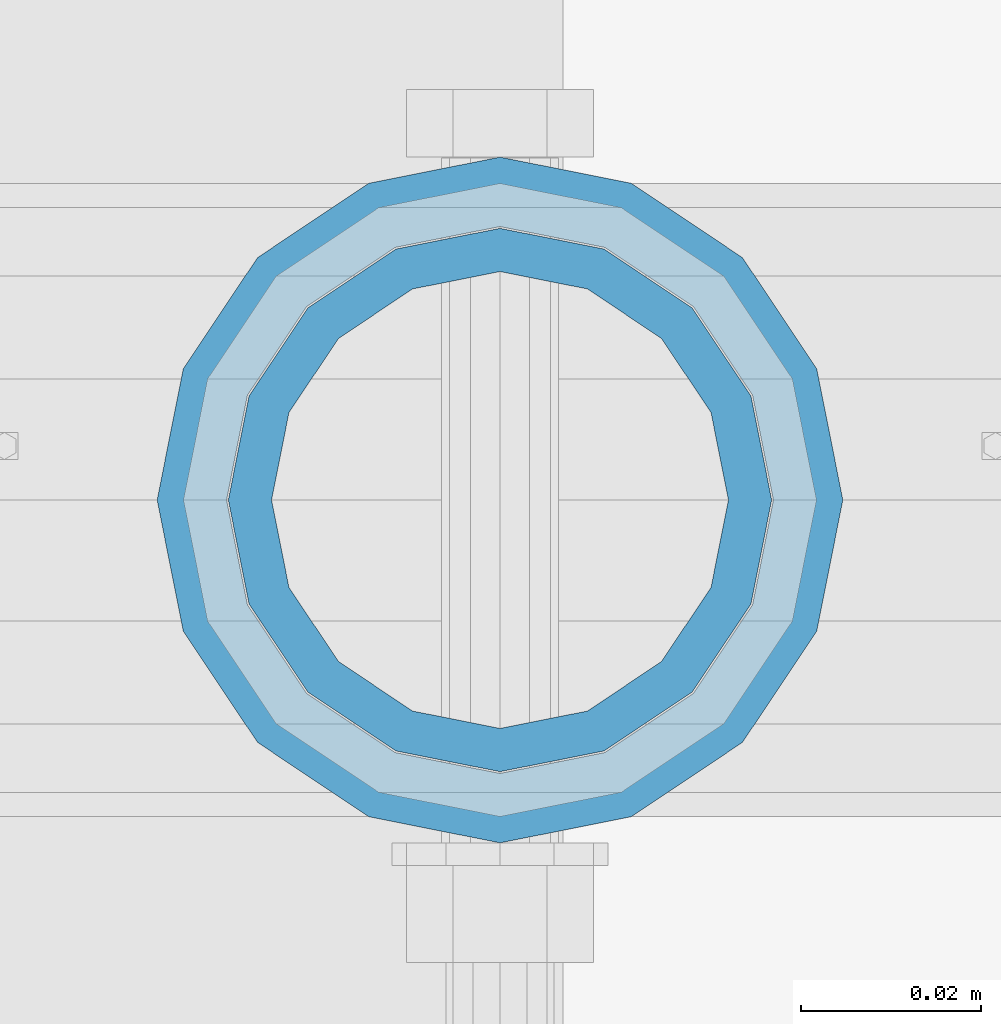
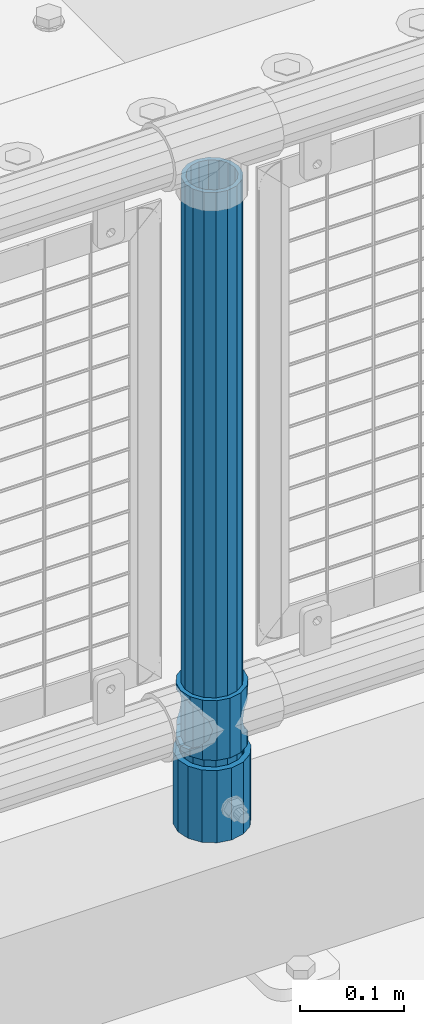
# One storey, part 67 of 193: 3 columns.
"""IFC2X3 building model written with IfcOpenShell, lengths in millimetres."""

from ifc_helpers import new_model, si_unit, frame, origin_with_axes, place, context, subcontext, project, spatial, faceted_brep, material, type_object, element, save


model = new_model("IFC2X3")

# Units and contexts
model_context = context("Model", 3, precision=1e-05, world=origin_with_axes())
body_context = subcontext(model_context, "Body", "Model", "MODEL_VIEW")
ifc_project = project(units=[si_unit("LENGTHUNIT", "METRE", prefix="MILLI"), si_unit("AREAUNIT", "SQUARE_METRE"), si_unit("VOLUMEUNIT", "CUBIC_METRE"), si_unit("MASSUNIT", "GRAM", prefix="KILO"), si_unit("TIMEUNIT", "SECOND"), si_unit("PLANEANGLEUNIT", "RADIAN"), si_unit("SOLIDANGLEUNIT", "STERADIAN"), si_unit("THERMODYNAMICTEMPERATUREUNIT", "DEGREE_CELSIUS"), si_unit("LUMINOUSINTENSITYUNIT", "LUMEN")], contexts=[model_context])

# Site, building, storey
site_placement = place(None, origin_with_axes())
site = spatial("IfcSite", under=ifc_project, at=site_placement, CompositionType="ELEMENT")
building_placement = place(site_placement, origin_with_axes())
building = spatial("IfcBuilding", under=site, at=building_placement, Name="Standard", CompositionType="ELEMENT")
storey_placement = place(building_placement, origin_with_axes())
storey = spatial("IfcBuildingStorey", under=building, at=storey_placement, Name="Undefined", CompositionType="ELEMENT", Elevation=0.0)

# Columns
ifc_material_1 = material(Name="Misc_Undefined")
column_type_1 = type_object("IfcColumnType", PredefinedType="NOTDEFINED")
column_1_placement = place(storey_placement, frame((-35197.0, 28664.5, 263.020000000001), z_axis=(-1.0, 0.0, 0.0), x_axis=(0.0, 0.0, 1.0)))
element("IfcColumn", 1, at=column_1_placement, inside=storey, type_object=column_type_1, material=ifc_material_1, context=body_context, shape_type="Brep", body=[
    faceted_brep([(56.6106908090114, 21.46069080901, -21.46069080901), (56.6106908090114, 21.46069080901, -27.1226768591041), (61.9623795176744, 13.4513226476338, -32.4743655677703), (63.1897438117172, 11.614442172282, -32.8397438117245), (63.1897438117172, 11.614442172282, -28.0397438117179), (46.7644421722801, 28.0397438117179, -11.614442172282), (46.7644421722801, 28.0397438117179, -20.0882031229849), (51.5310424080006, 24.8548033587067, -24.8548033587067), (35.1500000000015, 30.35, 0.0), (35.1499999999996, 30.3499999999985, -16.6306603983685), (23.5355578277192, 28.0397438117179, -11.614442172282), (23.5355578277192, 28.0397438117179, -20.0882031229849), (13.6893091909879, 21.46069080901, -21.46069080901), (13.6893091909879, 21.46069080901, -27.1226768591041), (18.7689575919987, 24.8548033587067, -24.8548033587067), (7.11025618828211, 11.614442172282, -28.0397438117179), (7.11025618828211, 11.614442172282, -32.8397438117245), (8.33762048232262, 13.4513226476338, -32.4743655677703), (4.79999999999961, 0.0, -30.3499999999985), (4.79999999999961, 0.0, -35.1500000000015), (7.11025618828211, -11.614442172282, -28.0397438117179), (7.11025618828211, -11.614442172282, -32.8397438117172), (13.6893091909879, -21.46069080901, -21.46069080901), (13.6893091909879, -21.46069080901, -27.1226768591114), (8.33762048232484, -13.4513226476338, -32.4743655677703), (23.5355578277191, -28.0397438117179, -11.614442172282), (23.5355578277191, -28.0397438117179, -20.0882031229812), (18.7689575919921, -24.8548033587067, -24.8548033587067), (35.1500000000015, -30.35, 0.0), (35.1499999999996, -30.3499999999985, -16.6306603983721), (46.7644421722801, -28.0397438117179, -11.614442172282), (46.7644421722801, -28.0397438117179, -20.0882031229812), (56.6106908090114, -21.46069080901, -21.46069080901), (56.6106908090114, -21.46069080901, -27.1226768591114), (51.5310424080006, -24.8548033587067, -24.8548033587067), (63.1897438117172, -11.614442172282, -28.0397438117179), (63.1897438117172, -11.614442172282, -32.8397438117172), (61.9623795176767, -13.4513226476338, -32.4743655677703), (65.4999999999997, 0.0, -30.3499999999985), (65.4999999999997, 0.0, -35.1500000000015), (0.0, -28.0397438117179, -11.614442172282), (0.0, -30.3499999999985, 0.0), (0.0, -21.46069080901, -21.46069080901), (0.0, -11.614442172282, -28.0397438117179), (0.0, 0.0, -30.3499999999985), (0.0, 11.614442172282, -28.0397438117179), (0.0, 21.46069080901, -21.46069080901), (0.0, 28.0397438117179, -11.614442172282), (0.0, 30.3499999999985, 0.0), (0.0, 28.0397438117179, 11.614442172282), (23.5355578277192, 28.0397438117179, 11.614442172282), (0.0, 21.46069080901, 21.46069080901), (13.6893091909879, 21.46069080901, 21.46069080901), (0.0, 11.614442172282, 28.0397438117179), (7.11025618828211, 11.614442172282, 28.0397438117179), (0.0, 0.0, 30.3499999999985), (4.79999999999961, 0.0, 30.3499999999985), (0.0, -11.614442172282, 28.0397438117179), (7.11025618828205, -11.614442172282, 28.0397438117179), (0.0, -21.46069080901, 21.46069080901), (13.6893091909879, -21.46069080901, 21.46069080901), (0.0, -28.0397438117179, 11.614442172282), (23.5355578277191, -28.0397438117179, 11.614442172282), (0.0, -32.4743655677703, 13.4513226476338), (0.0, -35.1500000000015, 0.0), (70.2999999999993, -35.1500000000015, 0.0), (70.2999999999993, -32.4743655677703, 13.4513226476338), (0.0, 13.4513226476338, -32.4743655677703), (0.0, 24.8548033587067, -24.8548033587067), (0.0, 0.0, -35.1500000000015), (0.0, -13.4513226476338, -32.4743655677703), (0.0, -24.8548033587067, -24.8548033587067), (0.0, -24.8548033587067, 24.8548033587067), (0.0, -13.4513226476338, 32.4743655677703), (0.0, 0.0, 35.1500000000015), (0.0, 13.4513226476338, 32.4743655677703), (0.0, 24.8548033587067, 24.8548033587067), (0.0, 32.4743655677703, 13.4513226476338), (0.0, 35.1500000000015, 0.0), (0.0, 32.4743655677703, -13.4513226476338), (0.0, -32.4743655677703, -13.4513226476338), (70.2999999999993, 32.4743655677703, 13.4513226476338), (70.2999999999993, 35.1500000000015, 0.0), (70.2999999999993, 32.4743655677703, -13.4513226476338), (70.2999999999993, 24.8548033587067, -24.8548033587067), (70.2999999999993, 13.4513226476338, -32.4743655677703), (70.2999999999993, 0.0, -35.1500000000015), (70.2999999999993, -13.4513226476338, -32.4743655677703), (70.2999999999993, -24.8548033587067, -24.8548033587067), (70.2999999999993, -32.4743655677703, -13.4513226476338), (70.2999999999993, 28.0397438117179, 11.614442172282), (70.2999999999993, 21.46069080901, 21.46069080901), (56.6106908090114, 21.46069080901, 21.46069080901), (46.7644421722801, 28.0397438117179, 11.614442172282), (70.2999999999993, 11.614442172282, 28.0397438117179), (63.1897438117172, 11.614442172282, 28.0397438117179), (70.2999999999993, 0.0, 30.3499999999985), (65.4999999999997, 0.0, 30.3499999999985), (70.2999999999993, -11.614442172282, 28.0397438117179), (63.1897438117172, -11.614442172282, 28.0397438117179), (70.2999999999993, -21.46069080901, 21.46069080901), (56.6106908090114, -21.46069080901, 21.46069080901), (70.2999999999993, -28.0397438117179, 11.614442172282), (46.7644421722801, -28.0397438117179, 11.614442172282), (70.2999999999993, -11.614442172282, -28.0397438117179), (70.2999999999993, 0.0, -30.3499999999985), (70.2999999999993, -21.46069080901, -21.46069080901), (70.2999999999993, -28.0397438117179, -11.614442172282), (70.2999999999993, -30.3499999999985, 0.0), (70.2999999999993, 24.8548033587067, 24.8548033587067), (70.2999999999993, 13.4513226476338, 32.4743655677703), (70.2999999999993, 0.0, 35.1500000000015), (70.2999999999993, -13.4513226476338, 32.4743655677703), (70.2999999999993, -24.8548033587067, 24.8548033587067), (70.2999999999993, 30.3499999999985, 0.0), (70.2999999999993, 28.0397438117179, -11.614442172282), (70.2999999999993, 21.46069080901, -21.46069080901), (70.2999999999993, 11.614442172282, -28.0397438117179), (61.9623795176742, 13.4513226476338, 32.4743655677703), (51.5310424080006, 24.8548033587067, 24.8548033587067), (56.6106908090114, 21.46069080901, 27.1226768591077), (65.4999999999997, 0.0, 35.1500000000015), (63.1897438117172, 11.614442172282, 32.8397438117136), (63.1897438117172, -11.614442172282, 32.8397438117136), (61.9623795176767, -13.4513226476338, 32.4743655677703), (56.6106908090114, -21.46069080901, 27.1226768591041), (51.5310424080006, -24.8548033587067, 24.8548033587067), (18.7689575919921, -24.8548033587067, 24.8548033587067), (46.7644421722801, -28.0397438117179, 20.0882031229812), (35.1499999999996, -30.3499999999985, 16.6306603983685), (23.5355578277191, -28.0397438117179, 20.0882031229812), (8.33762048232512, -13.4513226476338, 32.4743655677703), (13.6893091909879, -21.46069080901, 27.1226768591041), (4.79999999999961, 0.0, 35.1500000000015), (7.11025618828205, -11.614442172282, 32.8397438117136), (7.11025618828211, 11.614442172282, 32.8397438117136), (8.3376204823229, 13.4513226476338, 32.4743655677703), (13.6893091909879, 21.46069080901, 27.1226768591077), (18.7689575919987, 24.8548033587067, 24.8548033587067), (23.5355578277192, 28.0397438117179, 20.0882031229739), (35.1499999999996, 30.3499999999985, 16.6306603983576), (46.7644421722801, 28.0397438117179, 20.0882031229739)], [[[0, 1, 2, 3, 4]], [[5, 6, 7, 1, 0]], [[8, 9, 6, 5]], [[10, 11, 9, 8]], [[12, 13, 14, 11, 10]], [[15, 16, 17, 13, 12]], [[18, 19, 16, 15]], [[20, 21, 19, 18]], [[22, 23, 24, 21, 20]], [[25, 26, 27, 23, 22]], [[28, 29, 26, 25]], [[30, 31, 29, 28]], [[32, 33, 34, 31, 30]], [[35, 36, 37, 33, 32]], [[38, 39, 36, 35]], [[4, 3, 39, 38]], [[40, 41, 28, 25]], [[42, 40, 25, 22]], [[43, 42, 22, 20]], [[44, 43, 20, 18]], [[45, 44, 18, 15]], [[46, 45, 15, 12]], [[47, 46, 12, 10]], [[48, 47, 10, 8]], [[49, 48, 8, 50]], [[51, 49, 50, 52]], [[53, 51, 52, 54]], [[55, 53, 54, 56]], [[57, 55, 56, 58]], [[59, 57, 58, 60]], [[61, 59, 60, 62]], [[41, 61, 62, 28]], [[63, 64, 65, 66]], [[17, 67, 68, 14, 13]], [[19, 69, 67, 17, 16]], [[70, 69, 19, 21, 24]], [[71, 70, 24, 23, 27]], [[63, 72, 73, 74, 75, 76, 77, 78, 79, 68, 67, 69, 70, 71, 80, 64], [40, 42, 43, 44, 45, 46, 47, 48, 49, 51, 53, 55, 57, 59, 61, 41]], [[78, 77, 81, 82]], [[79, 78, 82, 83]], [[14, 68, 79, 83, 84, 7, 6, 9, 11]], [[84, 85, 2, 1, 7]], [[85, 86, 39, 3, 2]], [[37, 87, 88, 34, 33]], [[39, 86, 87, 37, 36]], [[34, 88, 89, 80, 71, 27, 26, 29, 31]], [[64, 80, 89, 65]], [[90, 91, 92, 93]], [[91, 94, 95, 92]], [[94, 96, 97, 95]], [[96, 98, 99, 97]], [[98, 100, 101, 99]], [[100, 102, 103, 101]], [[104, 105, 38, 35]], [[106, 104, 35, 32]], [[107, 106, 32, 30]], [[108, 107, 30, 28]], [[102, 108, 28, 103]], [[88, 87, 86, 85, 84, 83, 82, 81, 109, 110, 111, 112, 113, 66, 65, 89], [100, 98, 96, 94, 91, 90, 114, 115, 116, 117, 105, 104, 106, 107, 108, 102]], [[118, 110, 109, 119, 120]], [[121, 111, 110, 118, 122]], [[112, 111, 121, 123, 124]], [[113, 112, 124, 125, 126]], [[127, 72, 63, 66, 113, 126, 128, 129, 130]], [[131, 73, 72, 127, 132]], [[133, 74, 73, 131, 134]], [[75, 74, 133, 135, 136]], [[76, 75, 136, 137, 138]], [[119, 109, 81, 77, 76, 138, 139, 140, 141]], [[92, 120, 119, 141, 93]], [[95, 122, 118, 120, 92]], [[97, 121, 122, 95]], [[99, 123, 121, 97]], [[101, 125, 124, 123, 99]], [[103, 128, 126, 125, 101]], [[28, 129, 128, 103]], [[62, 130, 129, 28]], [[60, 132, 127, 130, 62]], [[58, 134, 131, 132, 60]], [[56, 133, 134, 58]], [[54, 135, 133, 56]], [[52, 137, 136, 135, 54]], [[50, 139, 138, 137, 52]], [[8, 140, 139, 50]], [[93, 141, 140, 8]], [[114, 90, 93, 8]], [[115, 114, 8, 5]], [[116, 115, 5, 0]], [[117, 116, 0, 4]], [[105, 117, 4, 38]]]),
])
ifc_material_2 = material()
column_type_2 = type_object("IfcColumnType", PredefinedType="NOTDEFINED")
column_2_placement = place(storey_placement, frame((-35197.0, 28664.5, 168.02), z_axis=(-1.0, 0.0, 0.0), x_axis=(0.0, 0.0, 1.0)))
element("IfcColumn", 2, at=column_2_placement, inside=storey, type_object=column_type_2, material=ifc_material_2, context=body_context, shape_type="Brep", body=[
    faceted_brep([(0.0, -25.3499999999985, 0.0), (0.0, -23.4203461491597, 9.70102501045403), (760.0, -23.4203461491597, 9.70102501045403), (760.0, -25.3499999999985, 0.0), (0.0, -17.9251569030785, 17.9251569030785), (760.0, -17.9251569030785, 17.9251569030785), (0.0, -9.70102501045403, 23.4203461491597), (760.0, -9.70102501045403, 23.4203461491597), (0.0, 0.0, 25.3499999999985), (760.0, 0.0, 25.3499999999985), (0.0, 9.70102501045403, 23.4203461491597), (760.0, 9.70102501045403, 23.4203461491597), (0.0, 17.9251569030785, 17.9251569030785), (760.0, 17.9251569030785, 17.9251569030785), (0.0, 23.4203461491597, 9.70102501045403), (760.0, 23.4203461491597, 9.70102501045403), (0.0, 25.3499999999985, 0.0), (760.0, 25.3499999999985, 0.0), (0.0, 23.4203461491597, -9.70102501045403), (760.0, 23.4203461491597, -9.70102501045403), (0.0, 17.9251569030785, -17.9251569030785), (760.0, 17.9251569030785, -17.9251569030785), (0.0, 9.70102501045403, -23.4203461491597), (760.0, 9.70102501045403, -23.4203461491597), (0.0, 0.0, -25.3499999999985), (760.0, 0.0, -25.3499999999985), (0.0, -9.70102501045403, -23.4203461491597), (760.0, -9.70102501045403, -23.4203461491597), (0.0, -17.9251569030785, -17.9251569030785), (760.0, -17.9251569030785, -17.9251569030785), (0.0, -23.4203461491597, -9.70102501045403), (760.0, -23.4203461491597, -9.70102501045403), (0.0, -30.1500000000015, 0.0), (0.0, -27.8549679052157, -11.5379054858058), (760.0, -27.8549679052157, -11.5379054858058), (760.0, -30.1500000000015, 0.0), (0.0, -21.3192694527752, -21.3192694527752), (760.0, -21.3192694527752, -21.3192694527752), (0.0, -11.5379054858058, -27.8549679052157), (760.0, -11.5379054858058, -27.8549679052157), (0.0, 0.0, -30.1500000000015), (760.0, 0.0, -30.1500000000015), (0.0, 11.5379054858058, -27.8549679052157), (760.0, 11.5379054858058, -27.8549679052157), (0.0, 21.3192694527752, -21.3192694527752), (760.0, 21.3192694527752, -21.3192694527752), (0.0, 27.8549679052157, -11.5379054858058), (760.0, 27.8549679052157, -11.5379054858058), (0.0, 30.1500000000015, 0.0), (760.0, 30.1500000000015, 0.0), (0.0, 27.8549679052157, 11.5379054858058), (760.0, 27.8549679052157, 11.5379054858058), (0.0, 21.3192694527752, 21.3192694527752), (760.0, 21.3192694527752, 21.3192694527752), (0.0, 11.5379054858058, 27.8549679052157), (760.0, 11.5379054858058, 27.8549679052157), (0.0, 0.0, 30.1500000000015), (760.0, 0.0, 30.1500000000015), (0.0, -11.5379054858058, 27.8549679052157), (760.0, -11.5379054858058, 27.8549679052157), (0.0, -21.3192694527752, 21.3192694527752), (760.0, -21.3192694527752, 21.3192694527752), (0.0, -27.8549679052157, 11.5379054858058), (760.0, -27.8549679052157, 11.5379054858058)], [[[0, 1, 2, 3]], [[1, 4, 5, 2]], [[4, 6, 7, 5]], [[6, 8, 9, 7]], [[8, 10, 11, 9]], [[10, 12, 13, 11]], [[12, 14, 15, 13]], [[14, 16, 17, 15]], [[16, 18, 19, 17]], [[18, 20, 21, 19]], [[20, 22, 23, 21]], [[22, 24, 25, 23]], [[24, 26, 27, 25]], [[26, 28, 29, 27]], [[28, 30, 31, 29]], [[30, 0, 3, 31]], [[32, 33, 34, 35]], [[33, 36, 37, 34]], [[36, 38, 39, 37]], [[38, 40, 41, 39]], [[40, 42, 43, 41]], [[42, 44, 45, 43]], [[44, 46, 47, 45]], [[46, 48, 49, 47]], [[48, 50, 51, 49]], [[50, 52, 53, 51]], [[52, 54, 55, 53]], [[54, 56, 57, 55]], [[56, 58, 59, 57]], [[58, 60, 61, 59]], [[60, 62, 63, 61]], [[62, 32, 35, 63]], [[37, 39, 41, 43, 45, 47, 49, 51, 53, 55, 57, 59, 61, 63, 35, 34], [5, 7, 9, 11, 13, 15, 17, 19, 21, 23, 25, 27, 29, 31, 3, 2]], [[62, 60, 58, 56, 54, 52, 50, 48, 46, 44, 42, 40, 38, 36, 33, 32], [30, 28, 26, 24, 22, 20, 18, 16, 14, 12, 10, 8, 6, 4, 1, 0]]]),
])
column_type_3 = type_object("IfcColumnType", PredefinedType="NOTDEFINED")
column_3_placement = place(storey_placement, frame((-35197.0, 28664.5, 168.02), z_axis=(0.0, 1.0, 0.0), x_axis=(0.0, 0.0, 1.0)))
element("IfcColumn", 3, at=column_3_placement, inside=storey, type_object=column_type_3, material=ifc_material_2, context=body_context, shape_type="Brep", body=[
    faceted_brep([(0.0, -31.75, 0.0), (0.0, -29.3331751572332, 12.1501989775934), (85.0, -29.3331751572332, 12.1501989775934), (85.0, -31.75, 0.0), (0.0, -22.4506403026717, 22.4506403026717), (85.0, -22.4506403026717, 22.4506403026717), (0.0, -12.1501989775934, 29.3331751572332), (85.0, -12.1501989775934, 29.3331751572332), (0.0, 0.0, 31.75), (85.0, 0.0, 31.75), (0.0, 12.1501989775934, 29.3331751572332), (85.0, 12.1501989775934, 29.3331751572332), (0.0, 22.4506403026717, 22.4506403026717), (85.0, 22.4506403026717, 22.4506403026717), (0.0, 29.3331751572332, 12.1501989775934), (85.0, 29.3331751572332, 12.1501989775934), (0.0, 31.75, 0.0), (85.0, 31.75, 0.0), (0.0, 29.3331751572332, -12.1501989775934), (85.0, 29.3331751572332, -12.1501989775934), (0.0, 22.4506403026717, -22.4506403026717), (85.0, 22.4506403026717, -22.4506403026717), (0.0, 12.1501989775934, -29.3331751572332), (85.0, 12.1501989775934, -29.3331751572332), (0.0, 0.0, -31.75), (85.0, 0.0, -31.75), (0.0, -12.1501989775934, -29.3331751572332), (85.0, -12.1501989775934, -29.3331751572332), (0.0, -22.4506403026717, -22.4506403026717), (85.0, -22.4506403026717, -22.4506403026717), (0.0, -29.3331751572332, -12.1501989775934), (85.0, -29.3331751572332, -12.1501989775934), (0.0, -38.0499999999993, 0.0), (0.0, -35.1536162120537, -14.5611046014928), (85.0, -35.1536162120537, -14.5611046014928), (85.0, -38.0499999999993, 0.0), (0.0, -26.9054130241493, -26.9054130241493), (85.0, -26.9054130241493, -26.9054130241493), (0.0, -14.5611046014928, -35.1536162120537), (85.0, -14.5611046014928, -35.1536162120537), (0.0, 0.0, -38.0499999999993), (85.0, 0.0, -38.0499999999993), (0.0, 14.5611046014928, -35.1536162120537), (85.0, 14.5611046014928, -35.1536162120537), (0.0, 26.9054130241493, -26.9054130241493), (85.0, 26.9054130241493, -26.9054130241493), (0.0, 35.1536162120537, -14.5611046014928), (85.0, 35.1536162120537, -14.5611046014928), (0.0, 38.0499999999993, 0.0), (85.0, 38.0499999999993, 0.0), (0.0, 35.1536162120537, 14.5611046014928), (85.0, 35.1536162120537, 14.5611046014928), (0.0, 26.9054130241493, 26.9054130241493), (85.0, 26.9054130241493, 26.9054130241493), (0.0, 14.5611046014928, 35.1536162120537), (85.0, 14.5611046014928, 35.1536162120537), (0.0, 0.0, 38.0499999999993), (85.0, 0.0, 38.0499999999993), (0.0, -14.5611046014928, 35.1536162120537), (85.0, -14.5611046014928, 35.1536162120537), (0.0, -26.9054130241493, 26.9054130241493), (85.0, -26.9054130241493, 26.9054130241493), (0.0, -35.1536162120537, 14.5611046014928), (85.0, -35.1536162120537, 14.5611046014928)], [[[0, 1, 2, 3]], [[1, 4, 5, 2]], [[4, 6, 7, 5]], [[6, 8, 9, 7]], [[8, 10, 11, 9]], [[10, 12, 13, 11]], [[12, 14, 15, 13]], [[14, 16, 17, 15]], [[16, 18, 19, 17]], [[18, 20, 21, 19]], [[20, 22, 23, 21]], [[22, 24, 25, 23]], [[24, 26, 27, 25]], [[26, 28, 29, 27]], [[28, 30, 31, 29]], [[30, 0, 3, 31]], [[32, 33, 34, 35]], [[33, 36, 37, 34]], [[36, 38, 39, 37]], [[38, 40, 41, 39]], [[40, 42, 43, 41]], [[42, 44, 45, 43]], [[44, 46, 47, 45]], [[46, 48, 49, 47]], [[48, 50, 51, 49]], [[50, 52, 53, 51]], [[52, 54, 55, 53]], [[54, 56, 57, 55]], [[56, 58, 59, 57]], [[58, 60, 61, 59]], [[60, 62, 63, 61]], [[62, 32, 35, 63]], [[37, 39, 41, 43, 45, 47, 49, 51, 53, 55, 57, 59, 61, 63, 35, 34], [5, 7, 9, 11, 13, 15, 17, 19, 21, 23, 25, 27, 29, 31, 3, 2]], [[62, 60, 58, 56, 54, 52, 50, 48, 46, 44, 42, 40, 38, 36, 33, 32], [30, 28, 26, 24, 22, 20, 18, 16, 14, 12, 10, 8, 6, 4, 1, 0]]]),
])

save(model, "model.ifc")
